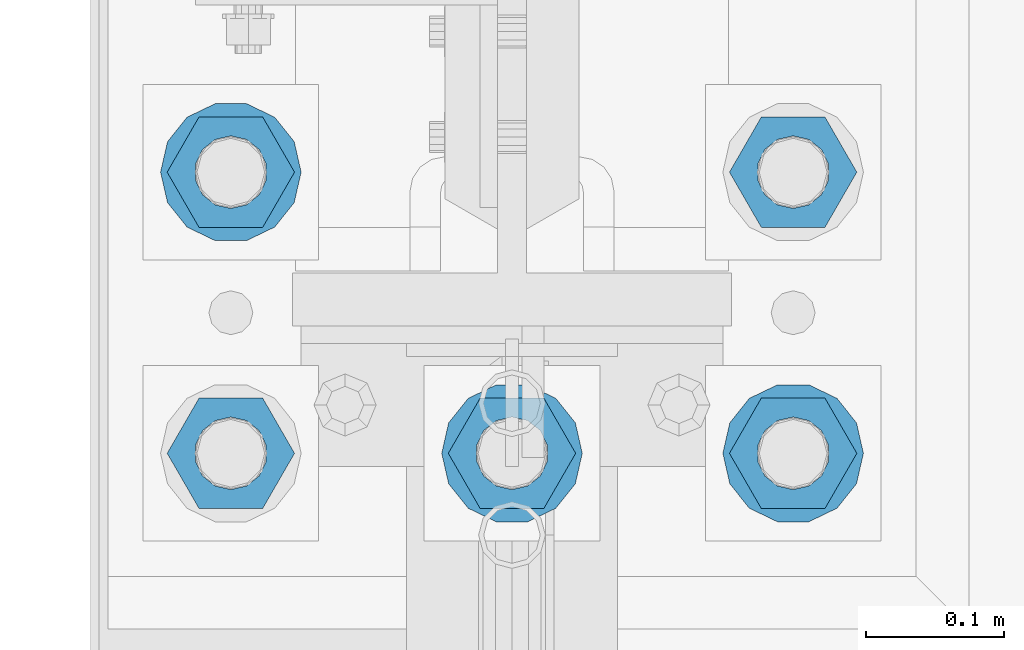
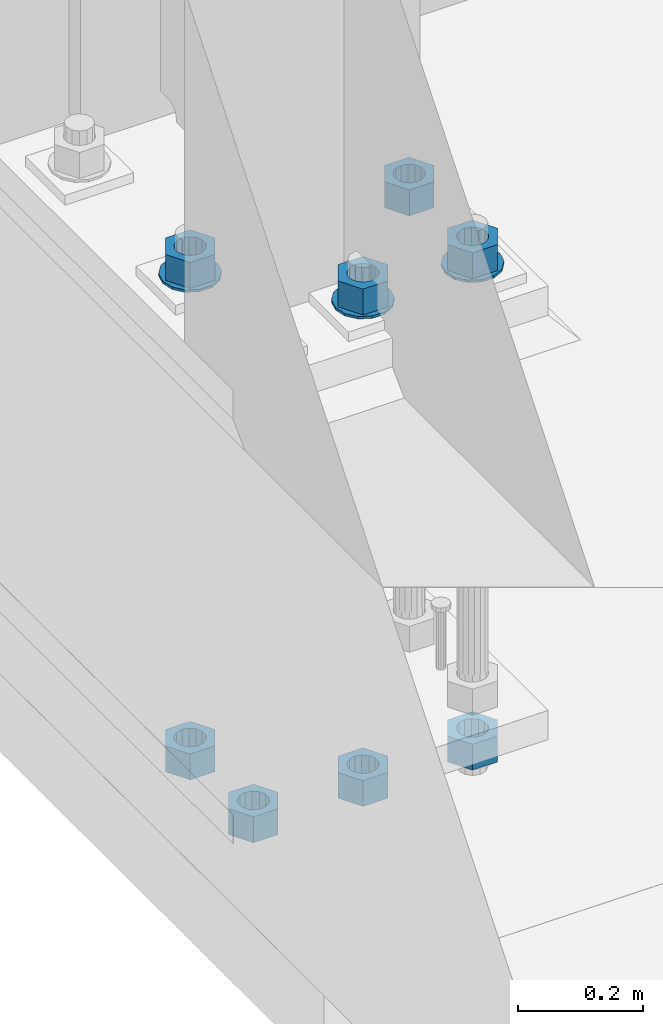
# One storey, part 835 of 1876: 11 columns, 1 element without a shape of its own.
"""IFC2X3 building model written with IfcOpenShell, lengths in millimetres."""

from ifc_helpers import new_model, si_unit, frame, origin_with_axes, place, context, subcontext, project, spatial, faceted_brep, material, type_object, element, aggregate, save


model = new_model("IFC2X3")

# Units and contexts
model_context = context("Model", 3, precision=1e-05, world=origin_with_axes())
body_context = subcontext(model_context, "Body", "Model", "MODEL_VIEW")
ifc_project = project(units=[si_unit("LENGTHUNIT", "METRE", prefix="MILLI"), si_unit("AREAUNIT", "SQUARE_METRE"), si_unit("VOLUMEUNIT", "CUBIC_METRE"), si_unit("MASSUNIT", "GRAM", prefix="KILO"), si_unit("TIMEUNIT", "SECOND"), si_unit("PLANEANGLEUNIT", "RADIAN"), si_unit("SOLIDANGLEUNIT", "STERADIAN"), si_unit("THERMODYNAMICTEMPERATUREUNIT", "DEGREE_CELSIUS"), si_unit("LUMINOUSINTENSITYUNIT", "LUMEN")], contexts=[model_context])

# Site, building, storey
site_placement = place(None, origin_with_axes())
site = spatial("IfcSite", under=ifc_project, at=site_placement, CompositionType="ELEMENT")
building_placement = place(site_placement, origin_with_axes())
building = spatial("IfcBuilding", under=site, at=building_placement, Name="Undefined", CompositionType="ELEMENT")
storey_placement = place(building_placement, origin_with_axes())
storey = spatial("IfcBuildingStorey", under=building, at=storey_placement, Name="Undefined", CompositionType="ELEMENT", Elevation=0.0)

# Assembly, columns
assembly_placement = place(storey_placement, origin_with_axes())
assembly = element("IfcElementAssembly", 1, at=assembly_placement, inside=storey, Name="TEMPLATE", AssemblyPlace="NOTDEFINED", PredefinedType="RIGID_FRAME")
ifc_material_1 = material(Name="STEEL/F436")
column_type_1 = type_object("IfcColumnType", Name="2_WASHER", PredefinedType="NOTDEFINED")
column_1_placement = place(assembly_placement, frame((0.0, 1143.0, 119.0625), z_axis=(0.0, -1.0, 0.0), x_axis=(0.0, 0.0, -1.0)))
column_1 = element("IfcColumn", 2, at=column_1_placement, type_object=column_type_1, material=ifc_material_1, Name="WASHER", ObjectType="2_WASHER", context=body_context, shape_type="Brep", body=[
    faceted_brep([(0.0, -50.7999992370605, 9.09494701772928e-13), (0.0, -45.7692178020588, -22.0412936161442), (4.7625, -45.7692178020588, -22.0412936161442), (4.7625, -50.7999992370605, 9.09494701772928e-13), (0.0, -31.6732814587394, -39.7170387128856), (4.7625, -31.6732814587394, -39.7170387128856), (0.0, -11.3040632752118, -49.5263371950259), (4.7625, -11.3040632752118, -49.5263371950259), (0.0, 11.30406327521, -49.5263371950264), (4.7625, 11.30406327521, -49.5263371950264), (0.0, 31.6732814587385, -39.7170387128867), (4.7625, 31.6732814587385, -39.7170387128867), (0.0, 45.7692178020579, -22.041293616146), (4.7625, 45.7692178020579, -22.041293616146), (0.0, 50.7999992370605, -9.09494701772928e-13), (4.7625, 50.7999992370605, -9.09494701772928e-13), (0.0, 45.7692178020588, 22.0412936161442), (4.7625, 45.7692178020588, 22.0412936161442), (0.0, 31.6732814587394, 39.7170387128856), (4.7625, 31.6732814587394, 39.7170387128856), (0.0, 11.3040632752118, 49.5263371950259), (4.7625, 11.3040632752118, 49.5263371950259), (0.0, -11.30406327521, 49.5263371950264), (4.7625, -11.30406327521, 49.5263371950264), (0.0, -31.6732814587385, 39.7170387128867), (4.7625, -31.6732814587385, 39.7170387128867), (0.0, -45.7692178020579, 22.041293616146), (4.7625, -45.7692178020579, 22.041293616146), (0.0, 0.0, 26.9869995117188), (0.0, 11.7093983825444, 24.3146012721213), (4.7625, 11.7093983825444, 24.3146012721213), (4.7625, 0.0, 26.9869995117188), (0.0, 21.0996520289491, 16.8262864224157), (4.7625, 21.0996520289491, 16.8262864224157), (0.0, 26.3108629296712, 6.00524193584533), (4.7625, 26.3108629296712, 6.00524193584533), (0.0, 26.3108629296712, -6.00524193584533), (4.7625, 26.3108629296712, -6.00524193584533), (0.0, 21.0996520289491, -16.8262864224157), (4.7625, 21.0996520289491, -16.8262864224157), (0.0, 11.7093983825444, -24.3146012721213), (4.7625, 11.7093983825444, -24.3146012721213), (0.0, 0.0, -26.9869995117188), (4.7625, 0.0, -26.9869995117188), (0.0, -11.7093983825444, -24.3146012721213), (4.7625, -11.7093983825444, -24.3146012721213), (0.0, -21.0996520289491, -16.8262864224157), (4.7625, -21.0996520289491, -16.8262864224157), (0.0, -26.3108629296712, -6.00524193584533), (4.7625, -26.3108629296712, -6.00524193584533), (0.0, -26.3108629296712, 6.00524193584533), (4.7625, -26.3108629296712, 6.00524193584533), (0.0, -21.0996520289491, 16.8262864224157), (4.7625, -21.0996520289491, 16.8262864224157), (0.0, -11.7093983825444, 24.3146012721213), (4.7625, -11.7093983825444, 24.3146012721213)], [[[0, 1, 2, 3]], [[1, 4, 5, 2]], [[4, 6, 7, 5]], [[6, 8, 9, 7]], [[8, 10, 11, 9]], [[10, 12, 13, 11]], [[12, 14, 15, 13]], [[14, 16, 17, 15]], [[16, 18, 19, 17]], [[18, 20, 21, 19]], [[20, 22, 23, 21]], [[22, 24, 25, 23]], [[24, 26, 27, 25]], [[26, 0, 3, 27]], [[28, 29, 30, 31]], [[29, 32, 33, 30]], [[32, 34, 35, 33]], [[34, 36, 37, 35]], [[36, 38, 39, 37]], [[38, 40, 41, 39]], [[40, 42, 43, 41]], [[42, 44, 45, 43]], [[44, 46, 47, 45]], [[46, 48, 49, 47]], [[48, 50, 51, 49]], [[50, 52, 53, 51]], [[52, 54, 55, 53]], [[54, 28, 31, 55]], [[5, 7, 9, 11, 13, 15, 17, 19, 21, 23, 25, 27, 3, 2], [33, 35, 37, 39, 41, 43, 45, 47, 49, 51, 53, 55, 31, 30]], [[26, 24, 22, 20, 18, 16, 14, 12, 10, 8, 6, 4, 1, 0], [54, 52, 50, 48, 46, 44, 42, 40, 38, 36, 34, 32, 29, 28]]]),
])
column_2_placement = place(assembly_placement, frame((203.2, 1143.0, 119.0625), z_axis=(0.0, 1.0, 0.0), x_axis=(0.0, 0.0, -1.0)))
column_2 = element("IfcColumn", 3, at=column_2_placement, type_object=column_type_1, material=ifc_material_1, Name="WASHER", ObjectType="2_WASHER", context=body_context, shape_type="Brep", body=[
    faceted_brep([(0.0, -50.7999992370605, 9.09494701772928e-13), (0.0, -45.7692178020588, -22.0412936161442), (4.7625, -45.7692178020588, -22.0412936161442), (4.7625, -50.7999992370605, 9.09494701772928e-13), (0.0, -31.6732814587394, -39.7170387128856), (4.7625, -31.6732814587394, -39.7170387128856), (0.0, -11.3040632752118, -49.5263371950259), (4.7625, -11.3040632752118, -49.5263371950259), (0.0, 11.30406327521, -49.5263371950264), (4.7625, 11.30406327521, -49.5263371950264), (0.0, 31.6732814587385, -39.7170387128867), (4.7625, 31.6732814587385, -39.7170387128867), (0.0, 45.7692178020579, -22.041293616146), (4.7625, 45.7692178020579, -22.041293616146), (0.0, 50.7999992370605, -9.09494701772928e-13), (4.7625, 50.7999992370605, -9.09494701772928e-13), (0.0, 45.7692178020588, 22.0412936161442), (4.7625, 45.7692178020588, 22.0412936161442), (0.0, 31.6732814587394, 39.7170387128856), (4.7625, 31.6732814587394, 39.7170387128856), (0.0, 11.3040632752118, 49.5263371950259), (4.7625, 11.3040632752118, 49.5263371950259), (0.0, -11.30406327521, 49.5263371950264), (4.7625, -11.30406327521, 49.5263371950264), (0.0, -31.6732814587385, 39.7170387128867), (4.7625, -31.6732814587385, 39.7170387128867), (0.0, -45.7692178020579, 22.041293616146), (4.7625, -45.7692178020579, 22.041293616146), (0.0, 0.0, 26.9869995117188), (0.0, 11.7093983825444, 24.3146012721213), (4.7625, 11.7093983825444, 24.3146012721213), (4.7625, 0.0, 26.9869995117188), (0.0, 21.0996520289491, 16.8262864224157), (4.7625, 21.0996520289491, 16.8262864224157), (0.0, 26.3108629296712, 6.00524193584533), (4.7625, 26.3108629296712, 6.00524193584533), (0.0, 26.3108629296712, -6.00524193584533), (4.7625, 26.3108629296712, -6.00524193584533), (0.0, 21.0996520289491, -16.8262864224157), (4.7625, 21.0996520289491, -16.8262864224157), (0.0, 11.7093983825444, -24.3146012721213), (4.7625, 11.7093983825444, -24.3146012721213), (0.0, 0.0, -26.9869995117188), (4.7625, 0.0, -26.9869995117188), (0.0, -11.7093983825444, -24.3146012721213), (4.7625, -11.7093983825444, -24.3146012721213), (0.0, -21.0996520289491, -16.8262864224157), (4.7625, -21.0996520289491, -16.8262864224157), (0.0, -26.3108629296712, -6.00524193584533), (4.7625, -26.3108629296712, -6.00524193584533), (0.0, -26.3108629296712, 6.00524193584533), (4.7625, -26.3108629296712, 6.00524193584533), (0.0, -21.0996520289491, 16.8262864224157), (4.7625, -21.0996520289491, 16.8262864224157), (0.0, -11.7093983825444, 24.3146012721213), (4.7625, -11.7093983825444, 24.3146012721213)], [[[0, 1, 2, 3]], [[1, 4, 5, 2]], [[4, 6, 7, 5]], [[6, 8, 9, 7]], [[8, 10, 11, 9]], [[10, 12, 13, 11]], [[12, 14, 15, 13]], [[14, 16, 17, 15]], [[16, 18, 19, 17]], [[18, 20, 21, 19]], [[20, 22, 23, 21]], [[22, 24, 25, 23]], [[24, 26, 27, 25]], [[26, 0, 3, 27]], [[28, 29, 30, 31]], [[29, 32, 33, 30]], [[32, 34, 35, 33]], [[34, 36, 37, 35]], [[36, 38, 39, 37]], [[38, 40, 41, 39]], [[40, 42, 43, 41]], [[42, 44, 45, 43]], [[44, 46, 47, 45]], [[46, 48, 49, 47]], [[48, 50, 51, 49]], [[50, 52, 53, 51]], [[52, 54, 55, 53]], [[54, 28, 31, 55]], [[5, 7, 9, 11, 13, 15, 17, 19, 21, 23, 25, 27, 3, 2], [33, 35, 37, 39, 41, 43, 45, 47, 49, 51, 53, 55, 31, 30]], [[26, 24, 22, 20, 18, 16, 14, 12, 10, 8, 6, 4, 1, 0], [54, 52, 50, 48, 46, 44, 42, 40, 38, 36, 34, 32, 29, 28]]]),
])
column_3_placement = place(assembly_placement, frame((-203.2, 1346.2, 119.0625), z_axis=(0.0, -1.0, 0.0), x_axis=(0.0, 0.0, -1.0)))
column_3 = element("IfcColumn", 4, at=column_3_placement, type_object=column_type_1, material=ifc_material_1, Name="WASHER", ObjectType="2_WASHER", context=body_context, shape_type="Brep", body=[
    faceted_brep([(0.0, -50.7999992370605, 9.09494701772928e-13), (0.0, -45.7692178020588, -22.0412936161442), (4.7625, -45.7692178020588, -22.0412936161442), (4.7625, -50.7999992370605, 9.09494701772928e-13), (0.0, -31.6732814587394, -39.7170387128856), (4.7625, -31.6732814587394, -39.7170387128856), (0.0, -11.3040632752118, -49.5263371950259), (4.7625, -11.3040632752118, -49.5263371950259), (0.0, 11.30406327521, -49.5263371950264), (4.7625, 11.30406327521, -49.5263371950264), (0.0, 31.6732814587385, -39.7170387128867), (4.7625, 31.6732814587385, -39.7170387128867), (0.0, 45.7692178020579, -22.041293616146), (4.7625, 45.7692178020579, -22.041293616146), (0.0, 50.7999992370605, -9.09494701772928e-13), (4.7625, 50.7999992370605, -9.09494701772928e-13), (0.0, 45.7692178020588, 22.0412936161442), (4.7625, 45.7692178020588, 22.0412936161442), (0.0, 31.6732814587394, 39.7170387128856), (4.7625, 31.6732814587394, 39.7170387128856), (0.0, 11.3040632752118, 49.5263371950259), (4.7625, 11.3040632752118, 49.5263371950259), (0.0, -11.30406327521, 49.5263371950264), (4.7625, -11.30406327521, 49.5263371950264), (0.0, -31.6732814587385, 39.7170387128867), (4.7625, -31.6732814587385, 39.7170387128867), (0.0, -45.7692178020579, 22.041293616146), (4.7625, -45.7692178020579, 22.041293616146), (0.0, 0.0, 26.9869995117188), (0.0, 11.7093983825444, 24.3146012721213), (4.7625, 11.7093983825444, 24.3146012721213), (4.7625, 0.0, 26.9869995117188), (0.0, 21.0996520289491, 16.8262864224157), (4.7625, 21.0996520289491, 16.8262864224157), (0.0, 26.3108629296712, 6.00524193584533), (4.7625, 26.3108629296712, 6.00524193584533), (0.0, 26.3108629296712, -6.00524193584533), (4.7625, 26.3108629296712, -6.00524193584533), (0.0, 21.0996520289491, -16.8262864224157), (4.7625, 21.0996520289491, -16.8262864224157), (0.0, 11.7093983825444, -24.3146012721213), (4.7625, 11.7093983825444, -24.3146012721213), (0.0, 0.0, -26.9869995117188), (4.7625, 0.0, -26.9869995117188), (0.0, -11.7093983825444, -24.3146012721213), (4.7625, -11.7093983825444, -24.3146012721213), (0.0, -21.0996520289491, -16.8262864224157), (4.7625, -21.0996520289491, -16.8262864224157), (0.0, -26.3108629296712, -6.00524193584533), (4.7625, -26.3108629296712, -6.00524193584533), (0.0, -26.3108629296712, 6.00524193584533), (4.7625, -26.3108629296712, 6.00524193584533), (0.0, -21.0996520289491, 16.8262864224157), (4.7625, -21.0996520289491, 16.8262864224157), (0.0, -11.7093983825444, 24.3146012721213), (4.7625, -11.7093983825444, 24.3146012721213)], [[[0, 1, 2, 3]], [[1, 4, 5, 2]], [[4, 6, 7, 5]], [[6, 8, 9, 7]], [[8, 10, 11, 9]], [[10, 12, 13, 11]], [[12, 14, 15, 13]], [[14, 16, 17, 15]], [[16, 18, 19, 17]], [[18, 20, 21, 19]], [[20, 22, 23, 21]], [[22, 24, 25, 23]], [[24, 26, 27, 25]], [[26, 0, 3, 27]], [[28, 29, 30, 31]], [[29, 32, 33, 30]], [[32, 34, 35, 33]], [[34, 36, 37, 35]], [[36, 38, 39, 37]], [[38, 40, 41, 39]], [[40, 42, 43, 41]], [[42, 44, 45, 43]], [[44, 46, 47, 45]], [[46, 48, 49, 47]], [[48, 50, 51, 49]], [[50, 52, 53, 51]], [[52, 54, 55, 53]], [[54, 28, 31, 55]], [[5, 7, 9, 11, 13, 15, 17, 19, 21, 23, 25, 27, 3, 2], [33, 35, 37, 39, 41, 43, 45, 47, 49, 51, 53, 55, 31, 30]], [[26, 24, 22, 20, 18, 16, 14, 12, 10, 8, 6, 4, 1, 0], [54, 52, 50, 48, 46, 44, 42, 40, 38, 36, 34, 32, 29, 28]]]),
])
ifc_material_2 = material(Name="STEEL/A563")
column_type_2 = type_object("IfcColumnType", Name="2_HEAVY_HEX_NUT", PredefinedType="NOTDEFINED")
column_4_placement = place(assembly_placement, frame((-203.2, 1143.0, -793.75), z_axis=(0.0, -1.0, 0.0), x_axis=(0.0, 0.0, -1.0)))
column_4 = element("IfcColumn", 5, at=column_4_placement, type_object=column_type_2, material=ifc_material_2, Name="NUT", ObjectType="2_HEAVY_HEX_NUT", context=body_context, shape_type="Brep", body=[
    faceted_brep([(0.0, -46.0369987487793, 9.09494701772928e-13), (0.0, -23.0184993743896, -39.869213104248), (50.8, -23.0184993743896, -39.869213104248), (50.8, -46.0369987487793, 9.09494701772928e-13), (0.0, 23.0184993743896, -39.869213104248), (50.8, 23.0184993743896, -39.869213104248), (0.0, 46.0369987487793, -9.09494701772928e-13), (50.8, 46.0369987487793, -9.09494701772928e-13), (0.0, 23.0184993743896, 39.869213104248), (50.8, 23.0184993743896, 39.869213104248), (0.0, -23.0184993743896, 39.869213104248), (50.8, -23.0184993743896, 39.869213104248), (0.0, 0.0, 26.1940002441406), (0.0, 11.3650617044514, 23.5999013092769), (50.8, 11.3650617044513, 23.5999013092771), (50.8, 0.0, 26.1940002441406), (0.0, 20.4791109456437, 16.3316083006703), (50.8, 20.4791109456439, 16.3316083006703), (0.0, 25.5370200498346, 5.82867859874477), (50.8, 25.5370200498343, 5.82867859874455), (0.0, 25.5370200498346, -5.82867859874477), (50.8, 25.5370200498343, -5.82867859874455), (0.0, 20.4791109456437, -16.3316083006703), (50.8, 20.4791109456439, -16.3316083006703), (0.0, 11.3650617044514, -23.5999013092769), (50.8, 11.3650617044514, -23.5999013092771), (0.0, 0.0, -26.1940002441406), (50.8, 0.0, -26.1940002441406), (0.0, -11.3650617044514, -23.5999013092769), (50.8, -11.3650617044513, -23.5999013092771), (0.0, -20.4791109456437, -16.3316083006703), (50.8, -20.4791109456439, -16.3316083006703), (0.0, -25.5370200498346, -5.82867859874477), (50.8, -25.5370200498343, -5.82867859874455), (0.0, -25.5370200498346, 5.82867859874477), (50.8, -25.5370200498343, 5.82867859874455), (0.0, -20.4791109456437, 16.3316083006703), (50.8, -20.4791109456439, 16.3316083006703), (0.0, -11.3650617044514, 23.5999013092769), (50.8, -11.3650617044514, 23.5999013092771)], [[[0, 1, 2, 3]], [[1, 4, 5, 2]], [[4, 6, 7, 5]], [[6, 8, 9, 7]], [[8, 10, 11, 9]], [[10, 0, 3, 11]], [[12, 13, 14, 15]], [[13, 16, 17, 14]], [[16, 18, 19, 17]], [[18, 20, 21, 19]], [[20, 22, 23, 21]], [[22, 24, 25, 23]], [[24, 26, 27, 25]], [[26, 28, 29, 27]], [[28, 30, 31, 29]], [[30, 32, 33, 31]], [[32, 34, 35, 33]], [[34, 36, 37, 35]], [[36, 38, 39, 37]], [[38, 12, 15, 39]], [[5, 7, 9, 11, 3, 2], [17, 19, 21, 23, 25, 27, 29, 31, 33, 35, 37, 39, 15, 14]], [[10, 8, 6, 4, 1, 0], [38, 36, 34, 32, 30, 28, 26, 24, 22, 20, 18, 16, 13, 12]]]),
])
column_5_placement = place(assembly_placement, frame((0.0, 1143.0, 169.8625), z_axis=(0.0, -1.0, 0.0), x_axis=(0.0, 0.0, -1.0)))
column_5 = element("IfcColumn", 6, at=column_5_placement, type_object=column_type_2, material=ifc_material_2, Name="NUT", ObjectType="2_HEAVY_HEX_NUT", context=body_context, shape_type="Brep", body=[
    faceted_brep([(0.0, -46.0369987487793, 9.09494701772928e-13), (0.0, -23.0184993743896, -39.869213104248), (50.8, -23.0184993743896, -39.869213104248), (50.8, -46.0369987487793, 9.09494701772928e-13), (0.0, 23.0184993743896, -39.869213104248), (50.8, 23.0184993743896, -39.869213104248), (0.0, 46.0369987487793, -9.09494701772928e-13), (50.8, 46.0369987487793, -9.09494701772928e-13), (0.0, 23.0184993743896, 39.869213104248), (50.8, 23.0184993743896, 39.869213104248), (0.0, -23.0184993743896, 39.869213104248), (50.8, -23.0184993743896, 39.869213104248), (0.0, 0.0, 26.1940002441406), (0.0, 11.3650617044514, 23.5999013092769), (50.8, 11.3650617044513, 23.5999013092771), (50.8, 0.0, 26.1940002441406), (0.0, 20.4791109456437, 16.3316083006703), (50.8, 20.4791109456439, 16.3316083006703), (0.0, 25.5370200498346, 5.82867859874477), (50.8, 25.5370200498343, 5.82867859874455), (0.0, 25.5370200498346, -5.82867859874477), (50.8, 25.5370200498343, -5.82867859874455), (0.0, 20.4791109456437, -16.3316083006703), (50.8, 20.4791109456439, -16.3316083006703), (0.0, 11.3650617044514, -23.5999013092769), (50.8, 11.3650617044514, -23.5999013092771), (0.0, 0.0, -26.1940002441406), (50.8, 0.0, -26.1940002441406), (0.0, -11.3650617044514, -23.5999013092769), (50.8, -11.3650617044513, -23.5999013092771), (0.0, -20.4791109456437, -16.3316083006703), (50.8, -20.4791109456439, -16.3316083006703), (0.0, -25.5370200498346, -5.82867859874477), (50.8, -25.5370200498343, -5.82867859874455), (0.0, -25.5370200498346, 5.82867859874477), (50.8, -25.5370200498343, 5.82867859874455), (0.0, -20.4791109456437, 16.3316083006703), (50.8, -20.4791109456439, 16.3316083006703), (0.0, -11.3650617044514, 23.5999013092769), (50.8, -11.3650617044514, 23.5999013092771)], [[[0, 1, 2, 3]], [[1, 4, 5, 2]], [[4, 6, 7, 5]], [[6, 8, 9, 7]], [[8, 10, 11, 9]], [[10, 0, 3, 11]], [[12, 13, 14, 15]], [[13, 16, 17, 14]], [[16, 18, 19, 17]], [[18, 20, 21, 19]], [[20, 22, 23, 21]], [[22, 24, 25, 23]], [[24, 26, 27, 25]], [[26, 28, 29, 27]], [[28, 30, 31, 29]], [[30, 32, 33, 31]], [[32, 34, 35, 33]], [[34, 36, 37, 35]], [[36, 38, 39, 37]], [[38, 12, 15, 39]], [[5, 7, 9, 11, 3, 2], [17, 19, 21, 23, 25, 27, 29, 31, 33, 35, 37, 39, 15, 14]], [[10, 8, 6, 4, 1, 0], [38, 36, 34, 32, 30, 28, 26, 24, 22, 20, 18, 16, 13, 12]]]),
])
column_6_placement = place(assembly_placement, frame((0.0, 1143.0, -793.75), z_axis=(0.0, -1.0, 0.0), x_axis=(0.0, 0.0, -1.0)))
column_6 = element("IfcColumn", 7, at=column_6_placement, type_object=column_type_2, material=ifc_material_2, Name="NUT", ObjectType="2_HEAVY_HEX_NUT", context=body_context, shape_type="Brep", body=[
    faceted_brep([(0.0, -46.0369987487793, 9.09494701772928e-13), (0.0, -23.0184993743896, -39.869213104248), (50.8, -23.0184993743896, -39.869213104248), (50.8, -46.0369987487793, 9.09494701772928e-13), (0.0, 23.0184993743896, -39.869213104248), (50.8, 23.0184993743896, -39.869213104248), (0.0, 46.0369987487793, -9.09494701772928e-13), (50.8, 46.0369987487793, -9.09494701772928e-13), (0.0, 23.0184993743896, 39.869213104248), (50.8, 23.0184993743896, 39.869213104248), (0.0, -23.0184993743896, 39.869213104248), (50.8, -23.0184993743896, 39.869213104248), (0.0, 0.0, 26.1940002441406), (0.0, 11.3650617044514, 23.5999013092769), (50.8, 11.3650617044513, 23.5999013092771), (50.8, 0.0, 26.1940002441406), (0.0, 20.4791109456437, 16.3316083006703), (50.8, 20.4791109456439, 16.3316083006703), (0.0, 25.5370200498346, 5.82867859874477), (50.8, 25.5370200498343, 5.82867859874455), (0.0, 25.5370200498346, -5.82867859874477), (50.8, 25.5370200498343, -5.82867859874455), (0.0, 20.4791109456437, -16.3316083006703), (50.8, 20.4791109456439, -16.3316083006703), (0.0, 11.3650617044514, -23.5999013092769), (50.8, 11.3650617044514, -23.5999013092771), (0.0, 0.0, -26.1940002441406), (50.8, 0.0, -26.1940002441406), (0.0, -11.3650617044514, -23.5999013092769), (50.8, -11.3650617044513, -23.5999013092771), (0.0, -20.4791109456437, -16.3316083006703), (50.8, -20.4791109456439, -16.3316083006703), (0.0, -25.5370200498346, -5.82867859874477), (50.8, -25.5370200498343, -5.82867859874455), (0.0, -25.5370200498346, 5.82867859874477), (50.8, -25.5370200498343, 5.82867859874455), (0.0, -20.4791109456437, 16.3316083006703), (50.8, -20.4791109456439, 16.3316083006703), (0.0, -11.3650617044514, 23.5999013092769), (50.8, -11.3650617044514, 23.5999013092771)], [[[0, 1, 2, 3]], [[1, 4, 5, 2]], [[4, 6, 7, 5]], [[6, 8, 9, 7]], [[8, 10, 11, 9]], [[10, 0, 3, 11]], [[12, 13, 14, 15]], [[13, 16, 17, 14]], [[16, 18, 19, 17]], [[18, 20, 21, 19]], [[20, 22, 23, 21]], [[22, 24, 25, 23]], [[24, 26, 27, 25]], [[26, 28, 29, 27]], [[28, 30, 31, 29]], [[30, 32, 33, 31]], [[32, 34, 35, 33]], [[34, 36, 37, 35]], [[36, 38, 39, 37]], [[38, 12, 15, 39]], [[5, 7, 9, 11, 3, 2], [17, 19, 21, 23, 25, 27, 29, 31, 33, 35, 37, 39, 15, 14]], [[10, 8, 6, 4, 1, 0], [38, 36, 34, 32, 30, 28, 26, 24, 22, 20, 18, 16, 13, 12]]]),
])
column_7_placement = place(assembly_placement, frame((203.2, 1143.0, 169.8625), z_axis=(0.0, 1.0, 0.0), x_axis=(0.0, 0.0, -1.0)))
column_7 = element("IfcColumn", 8, at=column_7_placement, type_object=column_type_2, material=ifc_material_2, Name="NUT", ObjectType="2_HEAVY_HEX_NUT", context=body_context, shape_type="Brep", body=[
    faceted_brep([(0.0, -46.0369987487793, 9.09494701772928e-13), (0.0, -23.0184993743896, -39.869213104248), (50.8, -23.0184993743896, -39.869213104248), (50.8, -46.0369987487793, 9.09494701772928e-13), (0.0, 23.0184993743896, -39.869213104248), (50.8, 23.0184993743896, -39.869213104248), (0.0, 46.0369987487793, -9.09494701772928e-13), (50.8, 46.0369987487793, -9.09494701772928e-13), (0.0, 23.0184993743896, 39.869213104248), (50.8, 23.0184993743896, 39.869213104248), (0.0, -23.0184993743896, 39.869213104248), (50.8, -23.0184993743896, 39.869213104248), (0.0, 0.0, 26.1940002441406), (0.0, 11.3650617044514, 23.5999013092769), (50.8, 11.3650617044513, 23.5999013092771), (50.8, 0.0, 26.1940002441406), (0.0, 20.4791109456437, 16.3316083006703), (50.8, 20.4791109456439, 16.3316083006703), (0.0, 25.5370200498346, 5.82867859874477), (50.8, 25.5370200498343, 5.82867859874455), (0.0, 25.5370200498346, -5.82867859874477), (50.8, 25.5370200498343, -5.82867859874455), (0.0, 20.4791109456437, -16.3316083006703), (50.8, 20.4791109456439, -16.3316083006703), (0.0, 11.3650617044514, -23.5999013092769), (50.8, 11.3650617044514, -23.5999013092771), (0.0, 0.0, -26.1940002441406), (50.8, 0.0, -26.1940002441406), (0.0, -11.3650617044514, -23.5999013092769), (50.8, -11.3650617044513, -23.5999013092771), (0.0, -20.4791109456437, -16.3316083006703), (50.8, -20.4791109456439, -16.3316083006703), (0.0, -25.5370200498346, -5.82867859874477), (50.8, -25.5370200498343, -5.82867859874455), (0.0, -25.5370200498346, 5.82867859874477), (50.8, -25.5370200498343, 5.82867859874455), (0.0, -20.4791109456437, 16.3316083006703), (50.8, -20.4791109456439, 16.3316083006703), (0.0, -11.3650617044514, 23.5999013092769), (50.8, -11.3650617044514, 23.5999013092771)], [[[0, 1, 2, 3]], [[1, 4, 5, 2]], [[4, 6, 7, 5]], [[6, 8, 9, 7]], [[8, 10, 11, 9]], [[10, 0, 3, 11]], [[12, 13, 14, 15]], [[13, 16, 17, 14]], [[16, 18, 19, 17]], [[18, 20, 21, 19]], [[20, 22, 23, 21]], [[22, 24, 25, 23]], [[24, 26, 27, 25]], [[26, 28, 29, 27]], [[28, 30, 31, 29]], [[30, 32, 33, 31]], [[32, 34, 35, 33]], [[34, 36, 37, 35]], [[36, 38, 39, 37]], [[38, 12, 15, 39]], [[5, 7, 9, 11, 3, 2], [17, 19, 21, 23, 25, 27, 29, 31, 33, 35, 37, 39, 15, 14]], [[10, 8, 6, 4, 1, 0], [38, 36, 34, 32, 30, 28, 26, 24, 22, 20, 18, 16, 13, 12]]]),
])
column_8_placement = place(assembly_placement, frame((203.2, 1143.0, -793.75), z_axis=(0.0, 1.0, 0.0), x_axis=(0.0, 0.0, -1.0)))
column_8 = element("IfcColumn", 9, at=column_8_placement, type_object=column_type_2, material=ifc_material_2, Name="NUT", ObjectType="2_HEAVY_HEX_NUT", context=body_context, shape_type="Brep", body=[
    faceted_brep([(0.0, -46.0369987487793, 9.09494701772928e-13), (0.0, -23.0184993743896, -39.869213104248), (50.8, -23.0184993743896, -39.869213104248), (50.8, -46.0369987487793, 9.09494701772928e-13), (0.0, 23.0184993743896, -39.869213104248), (50.8, 23.0184993743896, -39.869213104248), (0.0, 46.0369987487793, -9.09494701772928e-13), (50.8, 46.0369987487793, -9.09494701772928e-13), (0.0, 23.0184993743896, 39.869213104248), (50.8, 23.0184993743896, 39.869213104248), (0.0, -23.0184993743896, 39.869213104248), (50.8, -23.0184993743896, 39.869213104248), (0.0, 0.0, 26.1940002441406), (0.0, 11.3650617044514, 23.5999013092769), (50.8, 11.3650617044513, 23.5999013092771), (50.8, 0.0, 26.1940002441406), (0.0, 20.4791109456437, 16.3316083006703), (50.8, 20.4791109456439, 16.3316083006703), (0.0, 25.5370200498346, 5.82867859874477), (50.8, 25.5370200498343, 5.82867859874455), (0.0, 25.5370200498346, -5.82867859874477), (50.8, 25.5370200498343, -5.82867859874455), (0.0, 20.4791109456437, -16.3316083006703), (50.8, 20.4791109456439, -16.3316083006703), (0.0, 11.3650617044514, -23.5999013092769), (50.8, 11.3650617044514, -23.5999013092771), (0.0, 0.0, -26.1940002441406), (50.8, 0.0, -26.1940002441406), (0.0, -11.3650617044514, -23.5999013092769), (50.8, -11.3650617044513, -23.5999013092771), (0.0, -20.4791109456437, -16.3316083006703), (50.8, -20.4791109456439, -16.3316083006703), (0.0, -25.5370200498346, -5.82867859874477), (50.8, -25.5370200498343, -5.82867859874455), (0.0, -25.5370200498346, 5.82867859874477), (50.8, -25.5370200498343, 5.82867859874455), (0.0, -20.4791109456437, 16.3316083006703), (50.8, -20.4791109456439, 16.3316083006703), (0.0, -11.3650617044514, 23.5999013092769), (50.8, -11.3650617044514, 23.5999013092771)], [[[0, 1, 2, 3]], [[1, 4, 5, 2]], [[4, 6, 7, 5]], [[6, 8, 9, 7]], [[8, 10, 11, 9]], [[10, 0, 3, 11]], [[12, 13, 14, 15]], [[13, 16, 17, 14]], [[16, 18, 19, 17]], [[18, 20, 21, 19]], [[20, 22, 23, 21]], [[22, 24, 25, 23]], [[24, 26, 27, 25]], [[26, 28, 29, 27]], [[28, 30, 31, 29]], [[30, 32, 33, 31]], [[32, 34, 35, 33]], [[34, 36, 37, 35]], [[36, 38, 39, 37]], [[38, 12, 15, 39]], [[5, 7, 9, 11, 3, 2], [17, 19, 21, 23, 25, 27, 29, 31, 33, 35, 37, 39, 15, 14]], [[10, 8, 6, 4, 1, 0], [38, 36, 34, 32, 30, 28, 26, 24, 22, 20, 18, 16, 13, 12]]]),
])
column_9_placement = place(assembly_placement, frame((-203.2, 1346.2, 169.8625), z_axis=(0.0, -1.0, 0.0), x_axis=(0.0, 0.0, -1.0)))
column_9 = element("IfcColumn", 10, at=column_9_placement, type_object=column_type_2, material=ifc_material_2, Name="NUT", ObjectType="2_HEAVY_HEX_NUT", context=body_context, shape_type="Brep", body=[
    faceted_brep([(0.0, -46.0369987487793, 9.09494701772928e-13), (0.0, -23.0184993743896, -39.869213104248), (50.8, -23.0184993743896, -39.869213104248), (50.8, -46.0369987487793, 9.09494701772928e-13), (0.0, 23.0184993743896, -39.869213104248), (50.8, 23.0184993743896, -39.869213104248), (0.0, 46.0369987487793, -9.09494701772928e-13), (50.8, 46.0369987487793, -9.09494701772928e-13), (0.0, 23.0184993743896, 39.869213104248), (50.8, 23.0184993743896, 39.869213104248), (0.0, -23.0184993743896, 39.869213104248), (50.8, -23.0184993743896, 39.869213104248), (0.0, 0.0, 26.1940002441406), (0.0, 11.3650617044514, 23.5999013092769), (50.8, 11.3650617044513, 23.5999013092771), (50.8, 0.0, 26.1940002441406), (0.0, 20.4791109456437, 16.3316083006703), (50.8, 20.4791109456439, 16.3316083006703), (0.0, 25.5370200498346, 5.82867859874477), (50.8, 25.5370200498343, 5.82867859874455), (0.0, 25.5370200498346, -5.82867859874477), (50.8, 25.5370200498343, -5.82867859874455), (0.0, 20.4791109456437, -16.3316083006703), (50.8, 20.4791109456439, -16.3316083006703), (0.0, 11.3650617044514, -23.5999013092769), (50.8, 11.3650617044514, -23.5999013092771), (0.0, 0.0, -26.1940002441406), (50.8, 0.0, -26.1940002441406), (0.0, -11.3650617044514, -23.5999013092769), (50.8, -11.3650617044513, -23.5999013092771), (0.0, -20.4791109456437, -16.3316083006703), (50.8, -20.4791109456439, -16.3316083006703), (0.0, -25.5370200498346, -5.82867859874477), (50.8, -25.5370200498343, -5.82867859874455), (0.0, -25.5370200498346, 5.82867859874477), (50.8, -25.5370200498343, 5.82867859874455), (0.0, -20.4791109456437, 16.3316083006703), (50.8, -20.4791109456439, 16.3316083006703), (0.0, -11.3650617044514, 23.5999013092769), (50.8, -11.3650617044514, 23.5999013092771)], [[[0, 1, 2, 3]], [[1, 4, 5, 2]], [[4, 6, 7, 5]], [[6, 8, 9, 7]], [[8, 10, 11, 9]], [[10, 0, 3, 11]], [[12, 13, 14, 15]], [[13, 16, 17, 14]], [[16, 18, 19, 17]], [[18, 20, 21, 19]], [[20, 22, 23, 21]], [[22, 24, 25, 23]], [[24, 26, 27, 25]], [[26, 28, 29, 27]], [[28, 30, 31, 29]], [[30, 32, 33, 31]], [[32, 34, 35, 33]], [[34, 36, 37, 35]], [[36, 38, 39, 37]], [[38, 12, 15, 39]], [[5, 7, 9, 11, 3, 2], [17, 19, 21, 23, 25, 27, 29, 31, 33, 35, 37, 39, 15, 14]], [[10, 8, 6, 4, 1, 0], [38, 36, 34, 32, 30, 28, 26, 24, 22, 20, 18, 16, 13, 12]]]),
])
column_10_placement = place(assembly_placement, frame((-203.2, 1346.2, -793.75), z_axis=(0.0, -1.0, 0.0), x_axis=(0.0, 0.0, -1.0)))
column_10 = element("IfcColumn", 11, at=column_10_placement, type_object=column_type_2, material=ifc_material_2, Name="NUT", ObjectType="2_HEAVY_HEX_NUT", context=body_context, shape_type="Brep", body=[
    faceted_brep([(0.0, -46.0369987487793, 9.09494701772928e-13), (0.0, -23.0184993743896, -39.869213104248), (50.8, -23.0184993743896, -39.869213104248), (50.8, -46.0369987487793, 9.09494701772928e-13), (0.0, 23.0184993743896, -39.869213104248), (50.8, 23.0184993743896, -39.869213104248), (0.0, 46.0369987487793, -9.09494701772928e-13), (50.8, 46.0369987487793, -9.09494701772928e-13), (0.0, 23.0184993743896, 39.869213104248), (50.8, 23.0184993743896, 39.869213104248), (0.0, -23.0184993743896, 39.869213104248), (50.8, -23.0184993743896, 39.869213104248), (0.0, 0.0, 26.1940002441406), (0.0, 11.3650617044514, 23.5999013092769), (50.8, 11.3650617044513, 23.5999013092771), (50.8, 0.0, 26.1940002441406), (0.0, 20.4791109456437, 16.3316083006703), (50.8, 20.4791109456439, 16.3316083006703), (0.0, 25.5370200498346, 5.82867859874477), (50.8, 25.5370200498343, 5.82867859874455), (0.0, 25.5370200498346, -5.82867859874477), (50.8, 25.5370200498343, -5.82867859874455), (0.0, 20.4791109456437, -16.3316083006703), (50.8, 20.4791109456439, -16.3316083006703), (0.0, 11.3650617044514, -23.5999013092769), (50.8, 11.3650617044514, -23.5999013092771), (0.0, 0.0, -26.1940002441406), (50.8, 0.0, -26.1940002441406), (0.0, -11.3650617044514, -23.5999013092769), (50.8, -11.3650617044513, -23.5999013092771), (0.0, -20.4791109456437, -16.3316083006703), (50.8, -20.4791109456439, -16.3316083006703), (0.0, -25.5370200498346, -5.82867859874477), (50.8, -25.5370200498343, -5.82867859874455), (0.0, -25.5370200498346, 5.82867859874477), (50.8, -25.5370200498343, 5.82867859874455), (0.0, -20.4791109456437, 16.3316083006703), (50.8, -20.4791109456439, 16.3316083006703), (0.0, -11.3650617044514, 23.5999013092769), (50.8, -11.3650617044514, 23.5999013092771)], [[[0, 1, 2, 3]], [[1, 4, 5, 2]], [[4, 6, 7, 5]], [[6, 8, 9, 7]], [[8, 10, 11, 9]], [[10, 0, 3, 11]], [[12, 13, 14, 15]], [[13, 16, 17, 14]], [[16, 18, 19, 17]], [[18, 20, 21, 19]], [[20, 22, 23, 21]], [[22, 24, 25, 23]], [[24, 26, 27, 25]], [[26, 28, 29, 27]], [[28, 30, 31, 29]], [[30, 32, 33, 31]], [[32, 34, 35, 33]], [[34, 36, 37, 35]], [[36, 38, 39, 37]], [[38, 12, 15, 39]], [[5, 7, 9, 11, 3, 2], [17, 19, 21, 23, 25, 27, 29, 31, 33, 35, 37, 39, 15, 14]], [[10, 8, 6, 4, 1, 0], [38, 36, 34, 32, 30, 28, 26, 24, 22, 20, 18, 16, 13, 12]]]),
])
column_11_placement = place(assembly_placement, frame((203.2, 1346.2, 169.8625), z_axis=(0.0, 1.0, 0.0), x_axis=(0.0, 0.0, -1.0)))
column_11 = element("IfcColumn", 12, at=column_11_placement, type_object=column_type_2, material=ifc_material_2, Name="NUT", ObjectType="2_HEAVY_HEX_NUT", context=body_context, shape_type="Brep", body=[
    faceted_brep([(0.0, -46.0369987487793, 9.09494701772928e-13), (0.0, -23.0184993743896, -39.869213104248), (50.8, -23.0184993743896, -39.869213104248), (50.8, -46.0369987487793, 9.09494701772928e-13), (0.0, 23.0184993743896, -39.869213104248), (50.8, 23.0184993743896, -39.869213104248), (0.0, 46.0369987487793, -9.09494701772928e-13), (50.8, 46.0369987487793, -9.09494701772928e-13), (0.0, 23.0184993743896, 39.869213104248), (50.8, 23.0184993743896, 39.869213104248), (0.0, -23.0184993743896, 39.869213104248), (50.8, -23.0184993743896, 39.869213104248), (0.0, 0.0, 26.1940002441406), (0.0, 11.3650617044514, 23.5999013092769), (50.8, 11.3650617044513, 23.5999013092771), (50.8, 0.0, 26.1940002441406), (0.0, 20.4791109456437, 16.3316083006703), (50.8, 20.4791109456439, 16.3316083006703), (0.0, 25.5370200498346, 5.82867859874477), (50.8, 25.5370200498343, 5.82867859874455), (0.0, 25.5370200498346, -5.82867859874477), (50.8, 25.5370200498343, -5.82867859874455), (0.0, 20.4791109456437, -16.3316083006703), (50.8, 20.4791109456439, -16.3316083006703), (0.0, 11.3650617044514, -23.5999013092769), (50.8, 11.3650617044514, -23.5999013092771), (0.0, 0.0, -26.1940002441406), (50.8, 0.0, -26.1940002441406), (0.0, -11.3650617044514, -23.5999013092769), (50.8, -11.3650617044513, -23.5999013092771), (0.0, -20.4791109456437, -16.3316083006703), (50.8, -20.4791109456439, -16.3316083006703), (0.0, -25.5370200498346, -5.82867859874477), (50.8, -25.5370200498343, -5.82867859874455), (0.0, -25.5370200498346, 5.82867859874477), (50.8, -25.5370200498343, 5.82867859874455), (0.0, -20.4791109456437, 16.3316083006703), (50.8, -20.4791109456439, 16.3316083006703), (0.0, -11.3650617044514, 23.5999013092769), (50.8, -11.3650617044514, 23.5999013092771)], [[[0, 1, 2, 3]], [[1, 4, 5, 2]], [[4, 6, 7, 5]], [[6, 8, 9, 7]], [[8, 10, 11, 9]], [[10, 0, 3, 11]], [[12, 13, 14, 15]], [[13, 16, 17, 14]], [[16, 18, 19, 17]], [[18, 20, 21, 19]], [[20, 22, 23, 21]], [[22, 24, 25, 23]], [[24, 26, 27, 25]], [[26, 28, 29, 27]], [[28, 30, 31, 29]], [[30, 32, 33, 31]], [[32, 34, 35, 33]], [[34, 36, 37, 35]], [[36, 38, 39, 37]], [[38, 12, 15, 39]], [[5, 7, 9, 11, 3, 2], [17, 19, 21, 23, 25, 27, 29, 31, 33, 35, 37, 39, 15, 14]], [[10, 8, 6, 4, 1, 0], [38, 36, 34, 32, 30, 28, 26, 24, 22, 20, 18, 16, 13, 12]]]),
])
aggregate(assembly, [column_4, column_5, column_1, column_6, column_7, column_2, column_8, column_9, column_3, column_10, column_11])

save(model, "model.ifc")
